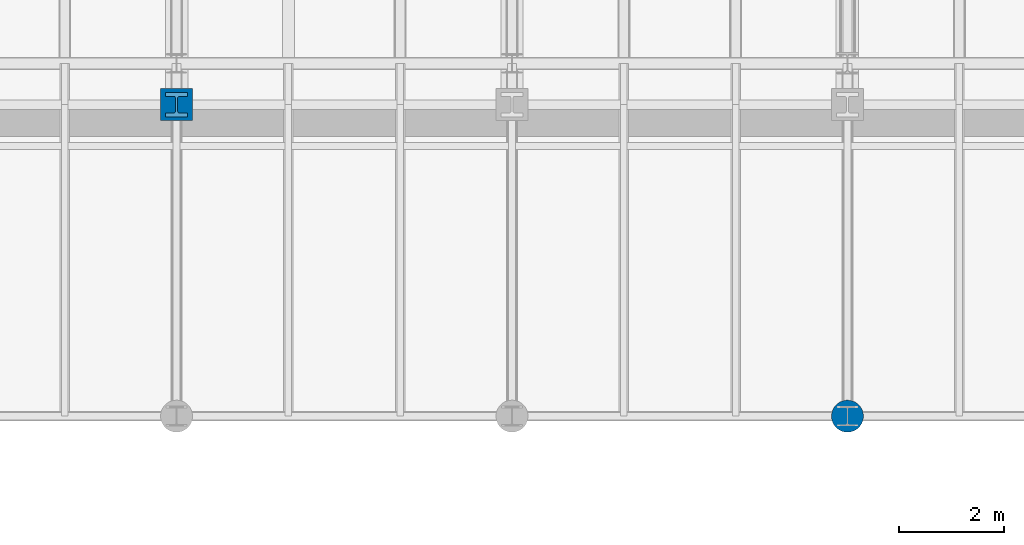
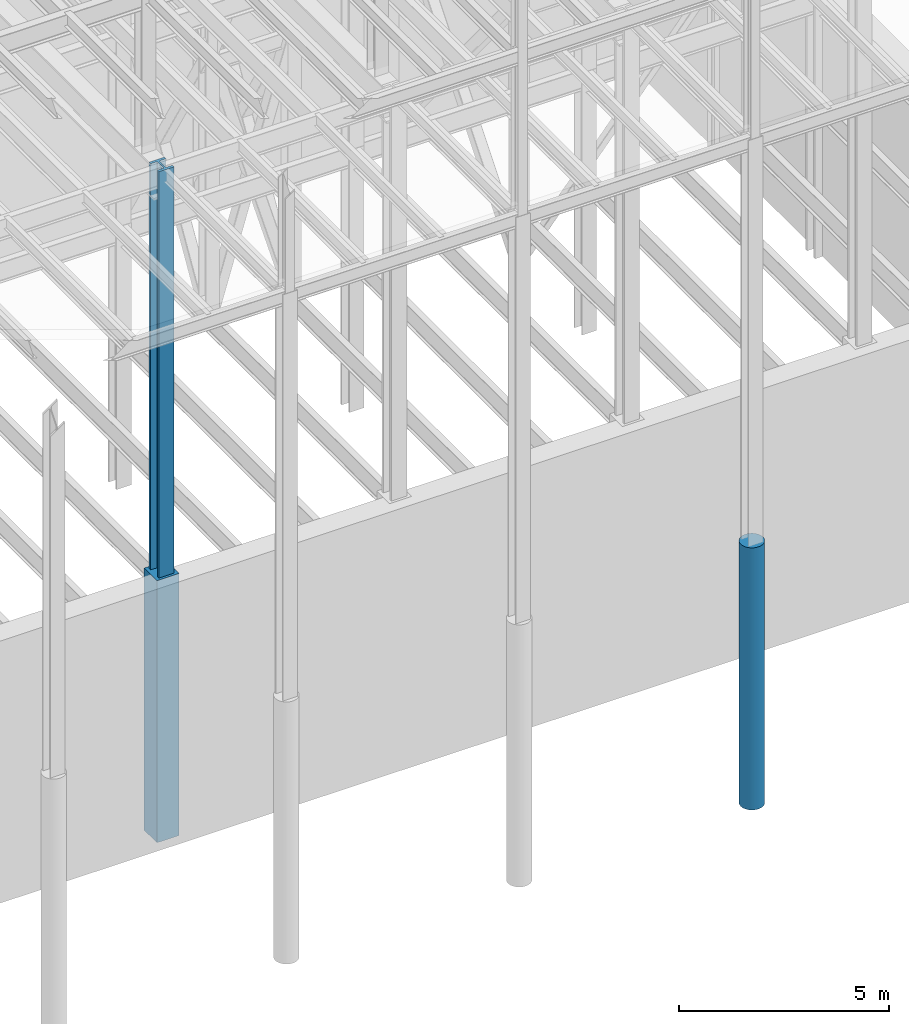
# One storey, part 75 of 150: 3 columns.
"""IFC2X3 building model written with IfcOpenShell, lengths in millimetres."""

from ifc_helpers import new_model, si_unit, frame, origin_with_axes, origin_2d_with_axis, place, context, subcontext, project, spatial, rectangle, circle, i_section, extrude, material, type_object, element, save


model = new_model("IFC2X3")

# Units and contexts
model_context = context("Model", 3, precision=1e-05, world=origin_with_axes())
body_context = subcontext(model_context, "Body", "Model", "MODEL_VIEW")
ifc_project = project(units=[si_unit("LENGTHUNIT", "METRE", prefix="MILLI"), si_unit("AREAUNIT", "SQUARE_METRE"), si_unit("VOLUMEUNIT", "CUBIC_METRE"), si_unit("MASSUNIT", "GRAM", prefix="KILO"), si_unit("TIMEUNIT", "SECOND"), si_unit("PLANEANGLEUNIT", "RADIAN"), si_unit("SOLIDANGLEUNIT", "STERADIAN"), si_unit("THERMODYNAMICTEMPERATUREUNIT", "DEGREE_CELSIUS"), si_unit("LUMINOUSINTENSITYUNIT", "LUMEN")], contexts=[model_context])

# Site, building, storey
site_placement = place(None, origin_with_axes())
site = spatial("IfcSite", under=ifc_project, at=site_placement, CompositionType="ELEMENT")
building_placement = place(site_placement, origin_with_axes())
building = spatial("IfcBuilding", under=site, at=building_placement, Name="Undefined", CompositionType="ELEMENT")
storey_placement = place(building_placement, origin_with_axes())
storey = spatial("IfcBuildingStorey", under=building, at=storey_placement, Name="Undefined", CompositionType="ELEMENT", Elevation=0.0)

# Columns
ifc_material_1 = material(Name="CONCRETE/5000")
column_type_1 = type_object("IfcColumnType", PredefinedType="NOTDEFINED")
column_1_placement = place(storey_placement, frame((75793.6, 3454.40000000001, 16154.4), z_axis=(0.0, 0.0, 1.0), x_axis=(1.0, 0.0, 0.0)))
element("IfcColumn", 1, at=column_1_placement, inside=storey, type_object=column_type_1, material=ifc_material_1, Name="COLUMN", context=body_context, shape_type="SweptSolid", body=[
    extrude(circle(Radius=304.8, at=origin_2d_with_axis()), frame((0.0, 0.0, 7620.0), z_axis=(0.0, 0.0, -1.0), x_axis=(0.0, -1.0, 0.0)), (0.0, 0.0, 1.0), 7620.0),
])
column_type_2 = type_object("IfcColumnType", PredefinedType="NOTDEFINED")
column_2_placement = place(storey_placement, frame((62992.0, 9398.0, 16154.4), z_axis=(0.0, 0.0, 1.0), x_axis=(1.0, 0.0, 0.0)))
element("IfcColumn", 2, at=column_2_placement, inside=storey, type_object=column_type_2, material=ifc_material_1, Name="COLUMN", context=body_context, shape_type="SweptSolid", body=[
    extrude(rectangle(XDim=609.6, YDim=609.6, at=origin_2d_with_axis()), frame((0.0, 0.0, 7620.0), z_axis=(0.0, 0.0, -1.0), x_axis=(0.0, -1.0, 0.0)), (0.0, 0.0, 1.0), 7620.0),
])
ifc_material_2 = material(Name="STEEL/A992")
column_type_3 = type_object("IfcColumnType", Name="W14X398", PredefinedType="NOTDEFINED")
column_3_placement = place(storey_placement, frame((62992.0, 9398.0, 22707.6), z_axis=(0.0, 0.0, 1.0), x_axis=(1.0, 0.0, 0.0)))
element("IfcColumn", 3, at=column_3_placement, inside=storey, type_object=column_type_3, material=ifc_material_2, Name="COLUMN", ObjectType="W14X398", context=body_context, shape_type="SweptSolid", body=[
    extrude(i_section(OverallWidth=421.64, OverallDepth=463.55, WebThickness=44.45, FlangeThickness=72.39, FilletRadius=32.512, at=origin_2d_with_axis()), frame((0.0, 0.0, 12877.8), z_axis=(0.0, 0.0, -1.0), x_axis=(-1.0, 0.0, 0.0)), (0.0, 0.0, 1.0), 12877.8),
])

save(model, "model.ifc")
